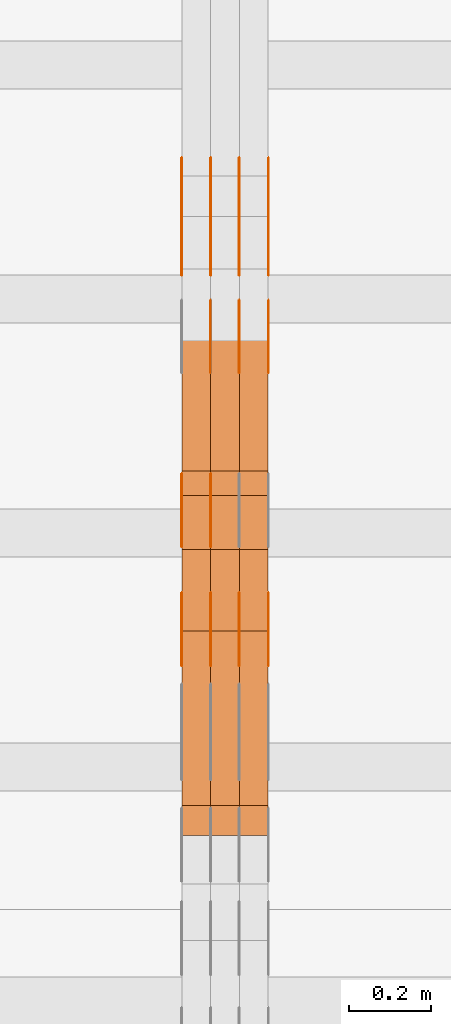
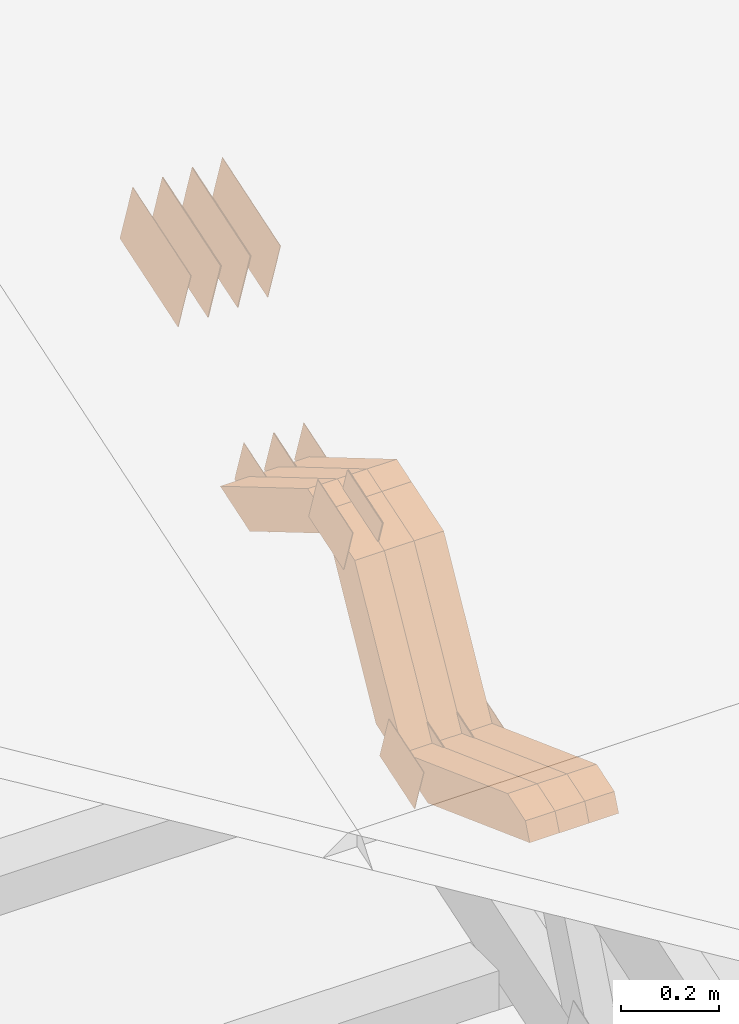
# One storey, part 137 of 385: 28 proxies.
"""IFC2X3 building model written with IfcOpenShell, lengths in millimetres."""

import ifcopenshell
import ifcopenshell.guid

model = None  # the IFC model being written
_history = None  # IfcOwnerHistory: only IFC2X3 demands one
_inside = {}  # id of a spatial element -> (the spatial element, [elements in it])
_under = {}  # id of a project, library or spatial element -> (it, [spatial elements below it])
_declared = {}  # id of a project -> (the project, [libraries it declares])
_typed = {}  # id of a type object -> (the type object, [elements of that type])
_made_of = {}  # id of a material, layer set ... -> (it, [elements and type objects made of it])


def new_model(schema):
    """Start an empty IFC model of exactly this schema.

    Asked for "IFC4X3", IfcOpenShell would pick the latest addendum, in which some entities
    have other attributes; the version numbers below select the first issue.
    IFC2X3 requires an IfcOwnerHistory on every rooted entity: one is made here for all.
    """
    global model, _history
    if schema == "IFC4X3":
        model = ifcopenshell.file(schema_version=(4, 3, 0, 0))
    else:
        model = ifcopenshell.file(schema=schema)
    _inside.clear()
    _under.clear()
    _declared.clear()
    _typed.clear()
    _made_of.clear()
    _history = None
    if model.schema == "IFC2X3":
        org = make("IfcOrganization", Name="unknown")
        user = make(
            "IfcPersonAndOrganization",
            ThePerson=make("IfcPerson", FamilyName="unknown"),
            TheOrganization=org,
        )
        app = make(
            "IfcApplication",
            ApplicationDeveloper=org,
            Version="unknown",
            ApplicationFullName="unknown",
            ApplicationIdentifier="unknown",
        )
        _history = make(
            "IfcOwnerHistory",
            OwningUser=user,
            OwningApplication=app,
            ChangeAction="ADDED",
            CreationDate=0,
        )
    return model


def make(cls, **values):
    """One entity of the class cls with the attributes given. An attribute that is None is left unset."""
    return model.create_entity(
        cls, **{name: value for name, value in values.items() if value is not None}
    )


def entity(cls, *values):
    """Any entity or typed value of the class cls, its attributes in the order of the schema. None: left unset."""
    e = model.create_entity(cls)
    for i, value in enumerate(values):
        if value is not None:
            e[i] = value
    return e


def rooted(cls, **values):
    """An entity with a GlobalId (a new one), such as an element, a storey or a relation."""
    return make(cls, GlobalId=ifcopenshell.guid.new(), OwnerHistory=_history, **values)


def si_unit(unit_type, name, prefix=None):
    """IfcSIUnit, for example si_unit("LENGTHUNIT", "METRE", prefix="MILLI")."""
    return make("IfcSIUnit", UnitType=unit_type, Prefix=prefix, Name=name)


def converted_unit(unit_type, name, factor, base, dimensions=None, offset=None):
    """IfcConversionBasedUnit, such as the inch: factor (a typed value) times the base unit."""
    return make(
        "IfcConversionBasedUnit"
        if offset is None
        else "IfcConversionBasedUnitWithOffset",
        ConversionOffset=offset,
        Dimensions=None
        if dimensions is None
        else entity("IfcDimensionalExponents", *dimensions),
        UnitType=unit_type,
        Name=name,
        ConversionFactor=make(
            "IfcMeasureWithUnit", ValueComponent=factor, UnitComponent=base
        ),
    )


def derived_unit(unit_type, elements):
    """IfcDerivedUnit: a product of units, each with its exponent."""
    return make(
        "IfcDerivedUnit",
        Elements=[
            make("IfcDerivedUnitElement", Unit=unit, Exponent=power)
            for unit, power in elements
        ],
        UnitType=unit_type,
    )


def assignment(units):
    """IfcUnitAssignment: the units of a project."""
    return None if units is None else make("IfcUnitAssignment", Units=units)


def point(xyz):
    """IfcCartesianPoint."""
    return None if xyz is None else make("IfcCartesianPoint", Coordinates=xyz)


def direction(xyz):
    """IfcDirection."""
    return None if xyz is None else make("IfcDirection", DirectionRatios=xyz)


def frame(location, z_axis=None, x_axis=None):
    """IfcAxis2Placement3D, a coordinate frame: its origin and axes. An axis left out is left unset."""
    return make(
        "IfcAxis2Placement3D",
        Location=point(location),
        Axis=direction(z_axis),
        RefDirection=direction(x_axis),
    )


def origin():
    """The frame at (0, 0, 0) with its axes left unset."""
    return frame((0.0, 0.0, 0.0))


def place(relative_to, where):
    """IfcLocalPlacement: puts the frame where relative to a parent placement (None: the world)."""
    return make(
        "IfcLocalPlacement", PlacementRelTo=relative_to, RelativePlacement=where
    )


def context(
    kind, dimensions, precision=None, world=None, true_north=None, identifier=None
):
    """IfcGeometricRepresentationContext, for example the 3D "Model" context."""
    return make(
        "IfcGeometricRepresentationContext",
        ContextIdentifier=identifier,
        ContextType=kind,
        CoordinateSpaceDimension=dimensions,
        Precision=precision,
        WorldCoordinateSystem=world,
        TrueNorth=true_north,
    )


def subcontext(parent, identifier, kind, view, scale=None):
    """IfcGeometricRepresentationSubContext, for example "Body" below "Model"."""
    return make(
        "IfcGeometricRepresentationSubContext",
        ContextIdentifier=identifier,
        ContextType=kind,
        ParentContext=parent,
        TargetScale=scale,
        TargetView=view,
    )


def project(units=None, contexts=None):
    """IfcProject with its units and contexts."""
    return rooted(
        "IfcProject",
        Name="project",
        RepresentationContexts=contexts,
        UnitsInContext=assignment(units),
    )


def spatial(cls, under=None, at=None, **own):
    """A site, building, storey or space (cls), placed at a placement, below another one or the project."""
    s = rooted(cls, ObjectPlacement=at, **own)
    if under is not None:
        _under.setdefault(under.id(), (under, []))[1].append(s)
    return s


def polyline(points):
    """IfcPolyline through the points."""
    return make("IfcPolyline", Points=[point(p) for p in points])


def outline(outer, holes=None, kind="AREA"):
    """IfcArbitraryClosedProfileDef: a profile drawn as a closed curve; with holes, ...WithVoids."""
    if holes is None:
        return make("IfcArbitraryClosedProfileDef", ProfileType=kind, OuterCurve=outer)
    return make(
        "IfcArbitraryProfileDefWithVoids",
        ProfileType=kind,
        OuterCurve=outer,
        InnerCurves=holes,
    )


def extrude(swept, where, along, depth):
    """IfcExtrudedAreaSolid: the profile swept, set in the frame where, extruded along a direction by depth."""
    return make(
        "IfcExtrudedAreaSolid",
        SweptArea=swept,
        Position=where,
        ExtrudedDirection=direction(along),
        Depth=depth,
    )


def shape(context_of_items, identifier, shape_type, items):
    """IfcShapeRepresentation: the items that make up one representation, for example the "Body"."""
    return make(
        "IfcShapeRepresentation",
        ContextOfItems=context_of_items,
        RepresentationIdentifier=identifier,
        RepresentationType=shape_type,
        Items=items,
    )


def source(mapping_origin, context_of_items, identifier, shape_type, items):
    """IfcRepresentationMap: a shape defined once, which mapped items show again and again."""
    return make(
        "IfcRepresentationMap",
        MappingOrigin=mapping_origin,
        MappedRepresentation=shape(context_of_items, identifier, shape_type, items),
    )


def transform(
    local_origin,
    x_axis=None,
    y_axis=None,
    z_axis=None,
    scale=None,
    scale2=None,
    scale3=None,
    uniform=True,
):
    """IfcCartesianTransformationOperator3D, or its non-uniform kind. x_axis, y_axis, z_axis: its Axis1, 2, 3."""
    if uniform:
        return make(
            "IfcCartesianTransformationOperator3D",
            Axis1=direction(x_axis),
            Axis2=direction(y_axis),
            LocalOrigin=point(local_origin),
            Scale=scale,
            Axis3=direction(z_axis),
        )
    return make(
        "IfcCartesianTransformationOperator3DnonUniform",
        Axis1=direction(x_axis),
        Axis2=direction(y_axis),
        LocalOrigin=point(local_origin),
        Scale=scale,
        Axis3=direction(z_axis),
        Scale2=scale2,
        Scale3=scale3,
    )


def mapped(mapping_source, mapping_target):
    """IfcMappedItem: shows the shape of a source again, moved by a transform."""
    return make(
        "IfcMappedItem", MappingSource=mapping_source, MappingTarget=mapping_target
    )


def material(Name=None, Category=None):
    """IfcMaterial."""
    return make("IfcMaterial", Name=Name, Category=Category)


def made_of(thing, what):
    """Note that an element or type object is made of a material, layer set ...; save() writes the relation."""
    if what is not None:
        _made_of.setdefault(what.id(), (what, []))[1].append(thing)
    return thing


def type_object(cls, material=None, **own):
    """A type object (cls), such as IfcWallType, which elements share."""
    return made_of(rooted(cls, **own), material)


def type_shapes(of_type, sources):
    """Give a type object the sources (RepresentationMaps) that its elements show as mapped items."""
    of_type.RepresentationMaps = sources


def element(
    cls,
    number,
    at=None,
    inside=None,
    cuts=None,
    type_object=None,
    material=None,
    context=None,
    identifier="Body",
    shape_type=None,
    held_by="IfcProductDefinitionShape",
    body=None,
    shapes=None,
    **own,
):
    """One element of the class cls, such as IfcWall. Its Tag is "e" and its number.

    at: its placement. inside: the storey or other place that contains it. cuts: it is an
    opening in that element (IfcRelVoidsElement). A single representation is given by context,
    identifier, shape_type and body (its items); several are given by shapes. held_by: the class
    of the entity that holds the representations. save() writes the other relations.
    """
    e = rooted(cls, Tag="e%d" % number, ObjectPlacement=at, **own)
    if body is not None:
        shapes = [shape(context, identifier, shape_type, body)]
    if shapes is not None:
        e.Representation = make(held_by, Representations=shapes)
    if inside is not None:
        _inside.setdefault(inside.id(), (inside, []))[1].append(e)
    if cuts is not None:
        rooted(
            "IfcRelVoidsElement", RelatingBuildingElement=cuts, RelatedOpeningElement=e
        )
    if type_object is not None:
        _typed.setdefault(type_object.id(), (type_object, []))[1].append(e)
    return made_of(e, material)


def aggregate(whole, parts):
    """IfcRelAggregates: a whole, such as a stair, and the parts it consists of."""
    return rooted("IfcRelAggregates", RelatingObject=whole, RelatedObjects=parts)


def save(model, path):
    """Write the relations noted so far, then the file.

    IfcRelAggregates (storeys below a building ...), IfcRelContainedInSpatialStructure (elements
    in a storey), IfcRelDefinesByType, IfcRelAssociatesMaterial and IfcRelDeclares: one each for
    every whole, place, type object, material and project.
    """
    for whole, parts in _under.values():
        aggregate(whole, parts)
    for where, things in _inside.values():
        rooted(
            "IfcRelContainedInSpatialStructure",
            RelatedElements=things,
            RelatingStructure=where,
        )
    for kind, things in _typed.values():
        rooted("IfcRelDefinesByType", RelatedObjects=things, RelatingType=kind)
    for what, things in _made_of.values():
        rooted("IfcRelAssociatesMaterial", RelatedObjects=things, RelatingMaterial=what)
    for by, libraries in _declared.values():
        rooted("IfcRelDeclares", RelatingContext=by, RelatedDefinitions=libraries)
    model.write(path)


model = new_model("IFC2X3")

# Units and contexts
model_context = context("Model", 3, precision=0.01, world=origin(), true_north=direction((6.12303176911189e-17, 1.0)))
body_context = subcontext(model_context, "Body", "Model", "MODEL_VIEW")
ifc_project = project(units=[si_unit("LENGTHUNIT", "METRE", prefix="MILLI"), si_unit("AREAUNIT", "SQUARE_METRE"), si_unit("VOLUMEUNIT", "CUBIC_METRE"), converted_unit("PLANEANGLEUNIT", "DEGREE", entity("IfcRatioMeasure", 0.0174532925199433), si_unit("PLANEANGLEUNIT", "RADIAN"), dimensions=[0, 0, 0, 0, 0, 0, 0]), si_unit("MASSUNIT", "GRAM", prefix="KILO"), derived_unit("MASSDENSITYUNIT", [(si_unit("MASSUNIT", "GRAM", prefix="KILO"), 1), (si_unit("LENGTHUNIT", "METRE"), -3)]), si_unit("TIMEUNIT", "SECOND"), si_unit("FREQUENCYUNIT", "HERTZ"), si_unit("THERMODYNAMICTEMPERATUREUNIT", "DEGREE_CELSIUS"), derived_unit("THERMALTRANSMITTANCEUNIT", [(si_unit("MASSUNIT", "GRAM", prefix="KILO"), 1), (si_unit("THERMODYNAMICTEMPERATUREUNIT", "KELVIN"), -1), (si_unit("TIMEUNIT", "SECOND"), -3)]), derived_unit("VOLUMETRICFLOWRATEUNIT", [(si_unit("LENGTHUNIT", "METRE"), 3), (si_unit("TIMEUNIT", "SECOND"), -1)]), si_unit("ELECTRICCURRENTUNIT", "AMPERE"), si_unit("ELECTRICVOLTAGEUNIT", "VOLT"), si_unit("POWERUNIT", "WATT"), si_unit("FORCEUNIT", "NEWTON", prefix="KILO"), si_unit("ILLUMINANCEUNIT", "LUX"), si_unit("LUMINOUSFLUXUNIT", "LUMEN"), si_unit("LUMINOUSINTENSITYUNIT", "CANDELA"), derived_unit("USERDEFINED", [(si_unit("MASSUNIT", "GRAM", prefix="KILO"), -1), (si_unit("LENGTHUNIT", "METRE"), -2), (si_unit("TIMEUNIT", "SECOND"), 3), (si_unit("LUMINOUSFLUXUNIT", "LUMEN"), 1)]), derived_unit("LINEARVELOCITYUNIT", [(si_unit("LENGTHUNIT", "METRE"), 1), (si_unit("TIMEUNIT", "SECOND"), -1)]), si_unit("PRESSUREUNIT", "PASCAL"), derived_unit("USERDEFINED", [(si_unit("LENGTHUNIT", "METRE"), -2), (si_unit("MASSUNIT", "GRAM", prefix="KILO"), 1), (si_unit("TIMEUNIT", "SECOND"), -2)])], contexts=[model_context])

# Site, building, storey
site_placement = place(None, origin())
site = spatial("IfcSite", under=ifc_project, at=site_placement, CompositionType="ELEMENT")
building_placement = place(site_placement, origin())
building = spatial("IfcBuilding", under=site, at=building_placement, CompositionType="ELEMENT")
storey_placement = place(building_placement, origin())
storey = spatial("IfcBuildingStorey", under=building, at=storey_placement, Name="Default", CompositionType="ELEMENT", Elevation=0.0)

# Proxies
ifc_material_1 = material(Name="IfcSurfaceStyle #348749")
building_element_proxy_type_1 = type_object("IfcBuildingElementProxyType", PredefinedType="NOTDEFINED", material=ifc_material_1)
shared_shape_1 = source(origin(), body_context, "Body", "SweptSolid", [
    extrude(outline(polyline([(-74.9998754286207, -60.0000016373506), (74.9998605591063, -60.0000016373506), (74.9998754286244, 60.0000016373506), (-74.9998605591099, 60.0000016373506), (-74.9998754286207, -60.0000016373506)])), frame((74.9998754286244, 60.0000016373506, 0.0), z_axis=(0.0, 0.0, 1.0), x_axis=(-1.0, 0.0, 0.0)), (0.0, 0.0, 1.0), 1.29999999999999),
])
type_shapes(building_element_proxy_type_1, [shared_shape_1])
proxy_1_placement = place(building_placement, frame((27245.0, 9580.89841427132, 2615.81135078741), z_axis=(-1.0, 0.0, 0.0), x_axis=(0.0, 0.951056516295154, 0.309016994374948)))
element("IfcBuildingElementProxy", 1, at=proxy_1_placement, inside=storey, type_object=building_element_proxy_type_1, material=ifc_material_1, context=body_context, shape_type="MappedRepresentation", body=[
    mapped(shared_shape_1, transform((0.0, 0.0, 0.0), scale=1.0)),
])
ifc_material_2 = material(Name="IfcSurfaceStyle #348692")
building_element_proxy_type_2 = type_object("IfcBuildingElementProxyType", PredefinedType="NOTDEFINED", material=ifc_material_2)
shared_shape_2 = source(origin(), body_context, "Body", "SweptSolid", [
    extrude(outline(polyline([(-74.9998754286207, -60.0000016373506), (74.9998605591063, -60.0000016373506), (74.9998754286244, 60.0000016373506), (-74.9998605591099, 60.0000016373506), (-74.9998754286207, -60.0000016373506)])), frame((74.9998754286244, 60.0000016373506, 0.0), z_axis=(0.0, 0.0, 1.0), x_axis=(-1.0, 0.0, 0.0)), (0.0, 0.0, 1.0), 1.29999999999999),
])
type_shapes(building_element_proxy_type_2, [shared_shape_2])
proxy_2_placement = place(building_placement, frame((27246.3, 9580.89841427132, 2615.81135078741), z_axis=(-1.0, 0.0, 0.0), x_axis=(0.0, 0.951056516295154, 0.309016994374948)))
element("IfcBuildingElementProxy", 2, at=proxy_2_placement, inside=storey, type_object=building_element_proxy_type_2, material=ifc_material_2, context=body_context, shape_type="MappedRepresentation", body=[
    mapped(shared_shape_2, transform((0.0, 0.0, 0.0), scale=1.0)),
])
ifc_material_3 = material(Name="IfcSurfaceStyle #348635")
building_element_proxy_type_3 = type_object("IfcBuildingElementProxyType", PredefinedType="NOTDEFINED", material=ifc_material_3)
shared_shape_3 = source(origin(), body_context, "Body", "SweptSolid", [
    extrude(outline(polyline([(-74.9998754286207, -60.0000016373506), (74.9998605591063, -60.0000016373506), (74.9998754286244, 60.0000016373506), (-74.9998605591099, 60.0000016373506), (-74.9998754286207, -60.0000016373506)])), frame((74.9998754286244, 60.0000016373506, 0.0), z_axis=(0.0, 0.0, 1.0), x_axis=(-1.0, 0.0, 0.0)), (0.0, 0.0, 1.0), 1.29999999999999),
])
type_shapes(building_element_proxy_type_3, [shared_shape_3])
proxy_3_placement = place(building_placement, frame((27175.0, 9580.89841427132, 2615.81135078741), z_axis=(-1.0, 0.0, 0.0), x_axis=(0.0, 0.951056516295154, 0.309016994374948)))
element("IfcBuildingElementProxy", 3, at=proxy_3_placement, inside=storey, type_object=building_element_proxy_type_3, material=ifc_material_3, context=body_context, shape_type="MappedRepresentation", body=[
    mapped(shared_shape_3, transform((0.0, 0.0, 0.0), scale=1.0)),
])
ifc_material_4 = material(Name="IfcSurfaceStyle #347894")
building_element_proxy_type_4 = type_object("IfcBuildingElementProxyType", PredefinedType="NOTDEFINED", material=ifc_material_4)
shared_shape_4 = source(origin(), body_context, "Body", "SweptSolid", [
    extrude(outline(polyline([(-75.0008041947458, -59.9996998629349), (75.0007893252423, -59.9996998629349), (75.0008041947458, 59.9996998629349), (-75.0007893252423, 59.9996998629349), (-75.0008041947458, -59.9996998629349)])), frame((75.0008041947458, 60.0002282421692, 0.0), z_axis=(0.0, 0.0, 1.0), x_axis=(-1.0, 0.0, 0.0)), (0.0, 0.0, 1.0), 1.3),
])
type_shapes(building_element_proxy_type_4, [shared_shape_4])
proxy_4_placement = place(building_placement, frame((27386.3, 9291.048828125, 2194.94482421875), z_axis=(-1.0, 0.0, 0.0), x_axis=(0.0, 0.951056516295124, 0.309016994375039)))
element("IfcBuildingElementProxy", 4, at=proxy_4_placement, inside=storey, type_object=building_element_proxy_type_4, material=ifc_material_4, context=body_context, shape_type="MappedRepresentation", body=[
    mapped(shared_shape_4, transform((0.0, 0.0, 0.0), scale=1.0)),
])
ifc_material_5 = material(Name="IfcSurfaceStyle #347837")
building_element_proxy_type_5 = type_object("IfcBuildingElementProxyType", PredefinedType="NOTDEFINED", material=ifc_material_5)
shared_shape_5 = source(origin(), body_context, "Body", "SweptSolid", [
    extrude(outline(polyline([(-75.0008041947458, -59.9996998629349), (75.0007893252423, -59.9996998629349), (75.0008041947458, 59.9996998629349), (-75.0007893252423, 59.9996998629349), (-75.0008041947458, -59.9996998629349)])), frame((75.0008041947458, 60.0002282421692, 0.0), z_axis=(0.0, 0.0, 1.0), x_axis=(-1.0, 0.0, 0.0)), (0.0, 0.0, 1.0), 1.3),
])
type_shapes(building_element_proxy_type_5, [shared_shape_5])
proxy_5_placement = place(building_placement, frame((27315.0, 9291.048828125, 2194.94482421875), z_axis=(-1.0, 0.0, 0.0), x_axis=(0.0, 0.951056516295124, 0.309016994375039)))
element("IfcBuildingElementProxy", 5, at=proxy_5_placement, inside=storey, type_object=building_element_proxy_type_5, material=ifc_material_5, context=body_context, shape_type="MappedRepresentation", body=[
    mapped(shared_shape_5, transform((0.0, 0.0, 0.0), scale=1.0)),
])
ifc_material_6 = material(Name="IfcSurfaceStyle #347780")
building_element_proxy_type_6 = type_object("IfcBuildingElementProxyType", PredefinedType="NOTDEFINED", material=ifc_material_6)
shared_shape_6 = source(origin(), body_context, "Body", "SweptSolid", [
    extrude(outline(polyline([(-75.0008041947458, -59.9996998629349), (75.0007893252423, -59.9996998629349), (75.0008041947458, 59.9996998629349), (-75.0007893252423, 59.9996998629349), (-75.0008041947458, -59.9996998629349)])), frame((75.0008041947458, 60.0002282421692, 0.0), z_axis=(0.0, 0.0, 1.0), x_axis=(-1.0, 0.0, 0.0)), (0.0, 0.0, 1.0), 1.3),
])
type_shapes(building_element_proxy_type_6, [shared_shape_6])
proxy_6_placement = place(building_placement, frame((27316.3, 9291.048828125, 2194.94482421875), z_axis=(-1.0, 0.0, 0.0), x_axis=(0.0, 0.951056516295124, 0.309016994375039)))
element("IfcBuildingElementProxy", 6, at=proxy_6_placement, inside=storey, type_object=building_element_proxy_type_6, material=ifc_material_6, context=body_context, shape_type="MappedRepresentation", body=[
    mapped(shared_shape_6, transform((0.0, 0.0, 0.0), scale=1.0)),
])
ifc_material_7 = material(Name="IfcSurfaceStyle #347723")
building_element_proxy_type_7 = type_object("IfcBuildingElementProxyType", PredefinedType="NOTDEFINED", material=ifc_material_7)
shared_shape_7 = source(origin(), body_context, "Body", "SweptSolid", [
    extrude(outline(polyline([(-75.0008041947458, -59.9996998629349), (75.0007893252423, -59.9996998629349), (75.0008041947458, 59.9996998629349), (-75.0007893252423, 59.9996998629349), (-75.0008041947458, -59.9996998629349)])), frame((75.0008041947458, 60.0002282421692, 0.0), z_axis=(0.0, 0.0, 1.0), x_axis=(-1.0, 0.0, 0.0)), (0.0, 0.0, 1.0), 1.29999999999999),
])
type_shapes(building_element_proxy_type_7, [shared_shape_7])
proxy_7_placement = place(building_placement, frame((27245.0, 9291.048828125, 2194.94482421875), z_axis=(-1.0, 0.0, 0.0), x_axis=(0.0, 0.951056516295124, 0.309016994375039)))
element("IfcBuildingElementProxy", 7, at=proxy_7_placement, inside=storey, type_object=building_element_proxy_type_7, material=ifc_material_7, context=body_context, shape_type="MappedRepresentation", body=[
    mapped(shared_shape_7, transform((0.0, 0.0, 0.0), scale=1.0)),
])
ifc_material_8 = material(Name="IfcSurfaceStyle #347666")
building_element_proxy_type_8 = type_object("IfcBuildingElementProxyType", PredefinedType="NOTDEFINED", material=ifc_material_8)
shared_shape_8 = source(origin(), body_context, "Body", "SweptSolid", [
    extrude(outline(polyline([(-75.0008041947458, -59.9996998629349), (75.0007893252423, -59.9996998629349), (75.0008041947458, 59.9996998629349), (-75.0007893252423, 59.9996998629349), (-75.0008041947458, -59.9996998629349)])), frame((75.0008041947458, 60.0002282421692, 0.0), z_axis=(0.0, 0.0, 1.0), x_axis=(-1.0, 0.0, 0.0)), (0.0, 0.0, 1.0), 1.29999999999999),
])
type_shapes(building_element_proxy_type_8, [shared_shape_8])
proxy_8_placement = place(building_placement, frame((27246.3, 9291.048828125, 2194.94482421875), z_axis=(-1.0, 0.0, 0.0), x_axis=(0.0, 0.951056516295124, 0.309016994375039)))
element("IfcBuildingElementProxy", 8, at=proxy_8_placement, inside=storey, type_object=building_element_proxy_type_8, material=ifc_material_8, context=body_context, shape_type="MappedRepresentation", body=[
    mapped(shared_shape_8, transform((0.0, 0.0, 0.0), scale=1.0)),
])
ifc_material_9 = material(Name="IfcSurfaceStyle #347609")
building_element_proxy_type_9 = type_object("IfcBuildingElementProxyType", PredefinedType="NOTDEFINED", material=ifc_material_9)
shared_shape_9 = source(origin(), body_context, "Body", "SweptSolid", [
    extrude(outline(polyline([(-75.0008041947458, -59.9996998629349), (75.0007893252423, -59.9996998629349), (75.0008041947458, 59.9996998629349), (-75.0007893252423, 59.9996998629349), (-75.0008041947458, -59.9996998629349)])), frame((75.0008041947458, 60.0002282421692, 0.0), z_axis=(0.0, 0.0, 1.0), x_axis=(-1.0, 0.0, 0.0)), (0.0, 0.0, 1.0), 1.29999999999999),
])
type_shapes(building_element_proxy_type_9, [shared_shape_9])
proxy_9_placement = place(building_placement, frame((27175.0, 9291.048828125, 2194.94482421875), z_axis=(-1.0, 0.0, 0.0), x_axis=(0.0, 0.951056516295124, 0.309016994375039)))
element("IfcBuildingElementProxy", 9, at=proxy_9_placement, inside=storey, type_object=building_element_proxy_type_9, material=ifc_material_9, context=body_context, shape_type="MappedRepresentation", body=[
    mapped(shared_shape_9, transform((0.0, 0.0, 0.0), scale=1.0)),
])
ifc_material_10 = material(Name="IfcSurfaceStyle #347552")
building_element_proxy_type_10 = type_object("IfcBuildingElementProxyType", PredefinedType="NOTDEFINED", material=ifc_material_10)
shared_shape_10 = source(origin(), body_context, "Body", "SweptSolid", [
    extrude(outline(polyline([(-124.999432723313, -83.9999457831645), (125.000177551971, -83.9999457831645), (124.999395001513, 83.9999457831646), (-125.000139830171, 83.9999457831645), (-124.999432723313, -83.9999457831645)])), frame((125.000177551971, 84.0001194377192, 0.0), z_axis=(0.0, 0.0, 1.0), x_axis=(-1.0, 0.0, 0.0)), (0.0, 0.0, 1.0), 1.3),
])
type_shapes(building_element_proxy_type_10, [shared_shape_10])
proxy_10_placement = place(building_placement, frame((27386.3, 10242.0968435407, 2855.88278137571), z_axis=(-1.0, 0.0, 0.0), x_axis=(0.0, 0.951056516295154, 0.309016994374948)))
element("IfcBuildingElementProxy", 10, at=proxy_10_placement, inside=storey, type_object=building_element_proxy_type_10, material=ifc_material_10, context=body_context, shape_type="MappedRepresentation", body=[
    mapped(shared_shape_10, transform((0.0, 0.0, 0.0), scale=1.0)),
])
ifc_material_11 = material(Name="IfcSurfaceStyle #347495")
building_element_proxy_type_11 = type_object("IfcBuildingElementProxyType", PredefinedType="NOTDEFINED", material=ifc_material_11)
shared_shape_11 = source(origin(), body_context, "Body", "SweptSolid", [
    extrude(outline(polyline([(-124.999432723313, -83.9999457831645), (125.000177551971, -83.9999457831645), (124.999395001513, 83.9999457831646), (-125.000139830171, 83.9999457831645), (-124.999432723313, -83.9999457831645)])), frame((125.000177551971, 84.0001194377192, 0.0), z_axis=(0.0, 0.0, 1.0), x_axis=(-1.0, 0.0, 0.0)), (0.0, 0.0, 1.0), 1.3),
])
type_shapes(building_element_proxy_type_11, [shared_shape_11])
proxy_11_placement = place(building_placement, frame((27315.0, 10242.0968435407, 2855.88278137571), z_axis=(-1.0, 0.0, 0.0), x_axis=(0.0, 0.951056516295154, 0.309016994374948)))
element("IfcBuildingElementProxy", 11, at=proxy_11_placement, inside=storey, type_object=building_element_proxy_type_11, material=ifc_material_11, context=body_context, shape_type="MappedRepresentation", body=[
    mapped(shared_shape_11, transform((0.0, 0.0, 0.0), scale=1.0)),
])
ifc_material_12 = material(Name="IfcSurfaceStyle #347438")
building_element_proxy_type_12 = type_object("IfcBuildingElementProxyType", PredefinedType="NOTDEFINED", material=ifc_material_12)
shared_shape_12 = source(origin(), body_context, "Body", "SweptSolid", [
    extrude(outline(polyline([(-124.999432723313, -83.9999457831645), (125.000177551971, -83.9999457831645), (124.999395001513, 83.9999457831646), (-125.000139830171, 83.9999457831645), (-124.999432723313, -83.9999457831645)])), frame((125.000177551971, 84.0001194377192, 0.0), z_axis=(0.0, 0.0, 1.0), x_axis=(-1.0, 0.0, 0.0)), (0.0, 0.0, 1.0), 1.3),
])
type_shapes(building_element_proxy_type_12, [shared_shape_12])
proxy_12_placement = place(building_placement, frame((27316.3, 10242.0968435407, 2855.88278137571), z_axis=(-1.0, 0.0, 0.0), x_axis=(0.0, 0.951056516295154, 0.309016994374948)))
element("IfcBuildingElementProxy", 12, at=proxy_12_placement, inside=storey, type_object=building_element_proxy_type_12, material=ifc_material_12, context=body_context, shape_type="MappedRepresentation", body=[
    mapped(shared_shape_12, transform((0.0, 0.0, 0.0), scale=1.0)),
])
ifc_material_13 = material(Name="IfcSurfaceStyle #347381")
building_element_proxy_type_13 = type_object("IfcBuildingElementProxyType", PredefinedType="NOTDEFINED", material=ifc_material_13)
shared_shape_13 = source(origin(), body_context, "Body", "SweptSolid", [
    extrude(outline(polyline([(-124.999432723313, -83.9999457831645), (125.000177551971, -83.9999457831645), (124.999395001513, 83.9999457831646), (-125.000139830171, 83.9999457831645), (-124.999432723313, -83.9999457831645)])), frame((125.000177551971, 84.0001194377192, 0.0), z_axis=(0.0, 0.0, 1.0), x_axis=(-1.0, 0.0, 0.0)), (0.0, 0.0, 1.0), 1.29999999999998),
])
type_shapes(building_element_proxy_type_13, [shared_shape_13])
proxy_13_placement = place(building_placement, frame((27245.0, 10242.0968435407, 2855.88278137571), z_axis=(-1.0, 0.0, 0.0), x_axis=(0.0, 0.951056516295154, 0.309016994374948)))
element("IfcBuildingElementProxy", 13, at=proxy_13_placement, inside=storey, type_object=building_element_proxy_type_13, material=ifc_material_13, context=body_context, shape_type="MappedRepresentation", body=[
    mapped(shared_shape_13, transform((0.0, 0.0, 0.0), scale=1.0)),
])
ifc_material_14 = material(Name="IfcSurfaceStyle #347324")
building_element_proxy_type_14 = type_object("IfcBuildingElementProxyType", PredefinedType="NOTDEFINED", material=ifc_material_14)
shared_shape_14 = source(origin(), body_context, "Body", "SweptSolid", [
    extrude(outline(polyline([(-124.999432723313, -83.9999457831645), (125.000177551971, -83.9999457831645), (124.999395001513, 83.9999457831646), (-125.000139830171, 83.9999457831645), (-124.999432723313, -83.9999457831645)])), frame((125.000177551971, 84.0001194377192, 0.0), z_axis=(0.0, 0.0, 1.0), x_axis=(-1.0, 0.0, 0.0)), (0.0, 0.0, 1.0), 1.29999999999998),
])
type_shapes(building_element_proxy_type_14, [shared_shape_14])
proxy_14_placement = place(building_placement, frame((27246.3, 10242.0968435407, 2855.88278137571), z_axis=(-1.0, 0.0, 0.0), x_axis=(0.0, 0.951056516295154, 0.309016994374948)))
element("IfcBuildingElementProxy", 14, at=proxy_14_placement, inside=storey, type_object=building_element_proxy_type_14, material=ifc_material_14, context=body_context, shape_type="MappedRepresentation", body=[
    mapped(shared_shape_14, transform((0.0, 0.0, 0.0), scale=1.0)),
])
ifc_material_15 = material(Name="IfcSurfaceStyle #347267")
building_element_proxy_type_15 = type_object("IfcBuildingElementProxyType", PredefinedType="NOTDEFINED", material=ifc_material_15)
shared_shape_15 = source(origin(), body_context, "Body", "SweptSolid", [
    extrude(outline(polyline([(-124.999432723313, -83.9999457831645), (125.000177551971, -83.9999457831645), (124.999395001513, 83.9999457831646), (-125.000139830171, 83.9999457831645), (-124.999432723313, -83.9999457831645)])), frame((125.000177551971, 84.0001194377192, 0.0), z_axis=(0.0, 0.0, 1.0), x_axis=(-1.0, 0.0, 0.0)), (0.0, 0.0, 1.0), 1.29999999999998),
])
type_shapes(building_element_proxy_type_15, [shared_shape_15])
proxy_15_placement = place(building_placement, frame((27175.0, 10242.0968435407, 2855.88278137571), z_axis=(-1.0, 0.0, 0.0), x_axis=(0.0, 0.951056516295154, 0.309016994374948)))
element("IfcBuildingElementProxy", 15, at=proxy_15_placement, inside=storey, type_object=building_element_proxy_type_15, material=ifc_material_15, context=body_context, shape_type="MappedRepresentation", body=[
    mapped(shared_shape_15, transform((0.0, 0.0, 0.0), scale=1.0)),
])
ifc_material_16 = material(Name="IfcSurfaceStyle #345842")
building_element_proxy_type_16 = type_object("IfcBuildingElementProxyType", PredefinedType="NOTDEFINED", material=ifc_material_16)
shared_shape_16 = source(origin(), body_context, "Body", "SweptSolid", [
    extrude(outline(polyline([(-74.9998754286189, -60.0000016373433), (74.9998605591118, -60.0000016373433), (74.9998754286189, 60.0000016373433), (-74.9998605591118, 60.0000016373433), (-74.9998754286189, -60.0000016373433)])), frame((74.9999131819004, 60.0000016373433, 0.0), z_axis=(0.0, 0.0, 1.0), x_axis=(-1.0, 0.0, 0.0)), (0.0, 0.0, 1.0), 1.3),
])
type_shapes(building_element_proxy_type_16, [shared_shape_16])
proxy_16_placement = place(building_placement, frame((27386.3, 10004.8612689908, 2426.87628052724), z_axis=(-1.0, 0.0, 0.0), x_axis=(0.0, 0.951056516295124, 0.309016994375039)))
element("IfcBuildingElementProxy", 16, at=proxy_16_placement, inside=storey, type_object=building_element_proxy_type_16, material=ifc_material_16, context=body_context, shape_type="MappedRepresentation", body=[
    mapped(shared_shape_16, transform((0.0, 0.0, 0.0), scale=1.0)),
])
ifc_material_17 = material(Name="IfcSurfaceStyle #345785")
building_element_proxy_type_17 = type_object("IfcBuildingElementProxyType", PredefinedType="NOTDEFINED", material=ifc_material_17)
shared_shape_17 = source(origin(), body_context, "Body", "SweptSolid", [
    extrude(outline(polyline([(-74.9998754286189, -60.0000016373433), (74.9998605591118, -60.0000016373433), (74.9998754286189, 60.0000016373433), (-74.9998605591118, 60.0000016373433), (-74.9998754286189, -60.0000016373433)])), frame((74.9999131819004, 60.0000016373433, 0.0), z_axis=(0.0, 0.0, 1.0), x_axis=(-1.0, 0.0, 0.0)), (0.0, 0.0, 1.0), 1.3),
])
type_shapes(building_element_proxy_type_17, [shared_shape_17])
proxy_17_placement = place(building_placement, frame((27315.0, 10004.8612689908, 2426.87628052724), z_axis=(-1.0, 0.0, 0.0), x_axis=(0.0, 0.951056516295124, 0.309016994375039)))
element("IfcBuildingElementProxy", 17, at=proxy_17_placement, inside=storey, type_object=building_element_proxy_type_17, material=ifc_material_17, context=body_context, shape_type="MappedRepresentation", body=[
    mapped(shared_shape_17, transform((0.0, 0.0, 0.0), scale=1.0)),
])
ifc_material_18 = material(Name="IfcSurfaceStyle #345728")
building_element_proxy_type_18 = type_object("IfcBuildingElementProxyType", PredefinedType="NOTDEFINED", material=ifc_material_18)
shared_shape_18 = source(origin(), body_context, "Body", "SweptSolid", [
    extrude(outline(polyline([(-74.9998754286189, -60.0000016373433), (74.9998605591118, -60.0000016373433), (74.9998754286189, 60.0000016373433), (-74.9998605591118, 60.0000016373433), (-74.9998754286189, -60.0000016373433)])), frame((74.9999131819004, 60.0000016373433, 0.0), z_axis=(0.0, 0.0, 1.0), x_axis=(-1.0, 0.0, 0.0)), (0.0, 0.0, 1.0), 1.3),
])
type_shapes(building_element_proxy_type_18, [shared_shape_18])
proxy_18_placement = place(building_placement, frame((27316.3, 10004.8612689908, 2426.87628052724), z_axis=(-1.0, 0.0, 0.0), x_axis=(0.0, 0.951056516295124, 0.309016994375039)))
element("IfcBuildingElementProxy", 18, at=proxy_18_placement, inside=storey, type_object=building_element_proxy_type_18, material=ifc_material_18, context=body_context, shape_type="MappedRepresentation", body=[
    mapped(shared_shape_18, transform((0.0, 0.0, 0.0), scale=1.0)),
])
ifc_material_19 = material(Name="IfcSurfaceStyle #345671")
building_element_proxy_type_19 = type_object("IfcBuildingElementProxyType", PredefinedType="NOTDEFINED", material=ifc_material_19)
shared_shape_19 = source(origin(), body_context, "Body", "SweptSolid", [
    extrude(outline(polyline([(-74.9998754286189, -60.0000016373433), (74.9998605591118, -60.0000016373433), (74.9998754286189, 60.0000016373433), (-74.9998605591118, 60.0000016373433), (-74.9998754286189, -60.0000016373433)])), frame((74.9999131819004, 60.0000016373433, 0.0), z_axis=(0.0, 0.0, 1.0), x_axis=(-1.0, 0.0, 0.0)), (0.0, 0.0, 1.0), 1.29999999999999),
])
type_shapes(building_element_proxy_type_19, [shared_shape_19])
proxy_19_placement = place(building_placement, frame((27245.0, 10004.8612689908, 2426.87628052724), z_axis=(-1.0, 0.0, 0.0), x_axis=(0.0, 0.951056516295124, 0.309016994375039)))
element("IfcBuildingElementProxy", 19, at=proxy_19_placement, inside=storey, type_object=building_element_proxy_type_19, material=ifc_material_19, context=body_context, shape_type="MappedRepresentation", body=[
    mapped(shared_shape_19, transform((0.0, 0.0, 0.0), scale=1.0)),
])
ifc_material_20 = material(Name="IfcSurfaceStyle #324728")
building_element_proxy_type_20 = type_object("IfcBuildingElementProxyType", Name="T1-W43 324726", PredefinedType="NOTDEFINED", material=ifc_material_20)
shared_shape_20 = source(origin(), body_context, "Body", "SweptSolid", [
    extrude(outline(polyline([(-198.159905426436, -47.4999961988362), (173.155878681738, -47.4999961988362), (174.585865234707, -0.00038778214839239), (132.582704932703, 47.5001900899104), (-282.164543422712, 47.5001900899104), (-198.159905426436, -47.4999961988362)])), frame((174.585865234707, 47.5001900899104, 0.0), z_axis=(0.0, 0.0, 1.0), x_axis=(-1.0, 0.0, 0.0)), (0.0, 0.0, 1.0), 70.0),
])
type_shapes(building_element_proxy_type_20, [shared_shape_20])
proxy_20_placement = place(building_placement, frame((27385.0, 9730.71877771152, 2634.4881681647), z_axis=(-1.0, 0.0, 0.0), x_axis=(0.0, 0.861495156633645, -0.507765787639115)))
element("IfcBuildingElementProxy", 20, at=proxy_20_placement, inside=storey, type_object=building_element_proxy_type_20, material=ifc_material_20, Name="T1-W43", context=body_context, shape_type="MappedRepresentation", body=[
    mapped(shared_shape_20, transform((0.0, 0.0, 0.0), scale=1.0)),
])
ifc_material_21 = material(Name="IfcSurfaceStyle #324662")
building_element_proxy_type_21 = type_object("IfcBuildingElementProxyType", Name="T1-W43 324660", PredefinedType="NOTDEFINED", material=ifc_material_21)
shared_shape_21 = source(origin(), body_context, "Body", "SweptSolid", [
    extrude(outline(polyline([(-198.159905426436, -47.4999961988362), (173.155878681738, -47.4999961988362), (174.585865234707, -0.00038778214839239), (132.582704932703, 47.5001900899104), (-282.164543422712, 47.5001900899104), (-198.159905426436, -47.4999961988362)])), frame((174.585865234707, 47.5001900899104, 0.0), z_axis=(0.0, 0.0, 1.0), x_axis=(-1.0, 0.0, 0.0)), (0.0, 0.0, 1.0), 70.0),
])
type_shapes(building_element_proxy_type_21, [shared_shape_21])
proxy_21_placement = place(building_placement, frame((27315.0, 9730.71877771152, 2634.4881681647), z_axis=(-1.0, 0.0, 0.0), x_axis=(0.0, 0.861495156633645, -0.507765787639115)))
element("IfcBuildingElementProxy", 21, at=proxy_21_placement, inside=storey, type_object=building_element_proxy_type_21, material=ifc_material_21, Name="T1-W43", context=body_context, shape_type="MappedRepresentation", body=[
    mapped(shared_shape_21, transform((0.0, 0.0, 0.0), scale=1.0)),
])
ifc_material_22 = material(Name="IfcSurfaceStyle #324596")
building_element_proxy_type_22 = type_object("IfcBuildingElementProxyType", Name="T1-W43 324594", PredefinedType="NOTDEFINED", material=ifc_material_22)
shared_shape_22 = source(origin(), body_context, "Body", "SweptSolid", [
    extrude(outline(polyline([(-198.159905426436, -47.4999961988362), (173.155878681738, -47.4999961988362), (174.585865234707, -0.00038778214839239), (132.582704932703, 47.5001900899104), (-282.164543422712, 47.5001900899104), (-198.159905426436, -47.4999961988362)])), frame((174.585865234707, 47.5001900899104, 0.0), z_axis=(0.0, 0.0, 1.0), x_axis=(-1.0, 0.0, 0.0)), (0.0, 0.0, 1.0), 70.0),
])
type_shapes(building_element_proxy_type_22, [shared_shape_22])
proxy_22_placement = place(building_placement, frame((27245.0, 9730.71877771152, 2634.4881681647), z_axis=(-1.0, 0.0, 0.0), x_axis=(0.0, 0.861495156633645, -0.507765787639115)))
element("IfcBuildingElementProxy", 22, at=proxy_22_placement, inside=storey, type_object=building_element_proxy_type_22, material=ifc_material_22, Name="T1-W43", context=body_context, shape_type="MappedRepresentation", body=[
    mapped(shared_shape_22, transform((0.0, 0.0, 0.0), scale=1.0)),
])
ifc_material_23 = material(Name="IfcSurfaceStyle #324332")
building_element_proxy_type_23 = type_object("IfcBuildingElementProxyType", Name="T1-W33 324330", PredefinedType="NOTDEFINED", material=ifc_material_23)
shared_shape_23 = source(origin(), body_context, "Body", "SweptSolid", [
    extrude(outline(polyline([(-314.173070820175, -47.4997758466969), (139.635944117881, -47.4997758466969), (190.204920608233, 0.000348187720347082), (197.369205310989, 47.5001702328475), (-213.036999216928, 47.4990332728259), (-314.173070820175, -47.4997758466969)])), frame((197.369205310989, 47.5001702328475, 0.0), z_axis=(0.0, 0.0, 1.0), x_axis=(-1.0, 0.0, 0.0)), (0.0, 0.0, 1.0), 70.0),
])
type_shapes(building_element_proxy_type_23, [shared_shape_23])
proxy_23_placement = place(building_placement, frame((27385.0, 9376.96875, 2191.01977539063), z_axis=(-1.0, 0.0, 0.0), x_axis=(0.0, 0.481632628948835, 0.876373214293907)))
element("IfcBuildingElementProxy", 23, at=proxy_23_placement, inside=storey, type_object=building_element_proxy_type_23, material=ifc_material_23, Name="T1-W33", context=body_context, shape_type="MappedRepresentation", body=[
    mapped(shared_shape_23, transform((0.0, 0.0, 0.0), scale=1.0)),
])
ifc_material_24 = material(Name="IfcSurfaceStyle #324266")
building_element_proxy_type_24 = type_object("IfcBuildingElementProxyType", Name="T1-W33 324264", PredefinedType="NOTDEFINED", material=ifc_material_24)
shared_shape_24 = source(origin(), body_context, "Body", "SweptSolid", [
    extrude(outline(polyline([(-314.173070820175, -47.4997758466969), (139.635944117881, -47.4997758466969), (190.204920608233, 0.000348187720347082), (197.369205310989, 47.5001702328475), (-213.036999216928, 47.4990332728259), (-314.173070820175, -47.4997758466969)])), frame((197.369205310989, 47.5001702328475, 0.0), z_axis=(0.0, 0.0, 1.0), x_axis=(-1.0, 0.0, 0.0)), (0.0, 0.0, 1.0), 70.0),
])
type_shapes(building_element_proxy_type_24, [shared_shape_24])
proxy_24_placement = place(building_placement, frame((27315.0, 9376.96875, 2191.01977539063), z_axis=(-1.0, 0.0, 0.0), x_axis=(0.0, 0.481632628948835, 0.876373214293907)))
element("IfcBuildingElementProxy", 24, at=proxy_24_placement, inside=storey, type_object=building_element_proxy_type_24, material=ifc_material_24, Name="T1-W33", context=body_context, shape_type="MappedRepresentation", body=[
    mapped(shared_shape_24, transform((0.0, 0.0, 0.0), scale=1.0)),
])
ifc_material_25 = material(Name="IfcSurfaceStyle #324200")
building_element_proxy_type_25 = type_object("IfcBuildingElementProxyType", Name="T1-W33 324198", PredefinedType="NOTDEFINED", material=ifc_material_25)
shared_shape_25 = source(origin(), body_context, "Body", "SweptSolid", [
    extrude(outline(polyline([(-314.173070820175, -47.4997758466969), (139.635944117881, -47.4997758466969), (190.204920608233, 0.000348187720347082), (197.369205310989, 47.5001702328475), (-213.036999216928, 47.4990332728259), (-314.173070820175, -47.4997758466969)])), frame((197.369205310989, 47.5001702328475, 0.0), z_axis=(0.0, 0.0, 1.0), x_axis=(-1.0, 0.0, 0.0)), (0.0, 0.0, 1.0), 70.0),
])
type_shapes(building_element_proxy_type_25, [shared_shape_25])
proxy_25_placement = place(building_placement, frame((27245.0, 9376.96875, 2191.01977539063), z_axis=(-1.0, 0.0, 0.0), x_axis=(0.0, 0.481632628948835, 0.876373214293907)))
element("IfcBuildingElementProxy", 25, at=proxy_25_placement, inside=storey, type_object=building_element_proxy_type_25, material=ifc_material_25, Name="T1-W33", context=body_context, shape_type="MappedRepresentation", body=[
    mapped(shared_shape_25, transform((0.0, 0.0, 0.0), scale=1.0)),
])
ifc_material_26 = material(Name="IfcSurfaceStyle #323936")
building_element_proxy_type_26 = type_object("IfcBuildingElementProxyType", Name="T1-W25 323934", PredefinedType="NOTDEFINED", material=ifc_material_26)
shared_shape_26 = source(origin(), body_context, "Body", "SweptSolid", [
    extrude(outline(polyline([(-229.232772462784, -47.5001671709529), (214.075939394384, -47.5001671709529), (212.688957821661, -0.000141058964427199), (152.358910178478, 47.5002377004352), (-349.891034931738, 47.5002377004352), (-229.232772462784, -47.5001671709529)])), frame((214.075939394384, 47.5002377004352, 0.0), z_axis=(0.0, 0.0, 1.0), x_axis=(-1.0, 0.0, 0.0)), (0.0, 0.0, 1.0), 70.0),
])
type_shapes(building_element_proxy_type_26, [shared_shape_26])
proxy_26_placement = place(building_placement, frame((27385.0, 8892.81895960242, 2369.29665807578), z_axis=(-1.0, 0.0, 0.0), x_axis=(0.0, 0.938402514401222, -0.345544094097213)))
element("IfcBuildingElementProxy", 26, at=proxy_26_placement, inside=storey, type_object=building_element_proxy_type_26, material=ifc_material_26, Name="T1-W25", context=body_context, shape_type="MappedRepresentation", body=[
    mapped(shared_shape_26, transform((0.0, 0.0, 0.0), scale=1.0)),
])
ifc_material_27 = material(Name="IfcSurfaceStyle #323870")
building_element_proxy_type_27 = type_object("IfcBuildingElementProxyType", Name="T1-W25 323868", PredefinedType="NOTDEFINED", material=ifc_material_27)
shared_shape_27 = source(origin(), body_context, "Body", "SweptSolid", [
    extrude(outline(polyline([(-229.232772462784, -47.5001671709529), (214.075939394384, -47.5001671709529), (212.688957821661, -0.000141058964427199), (152.358910178478, 47.5002377004352), (-349.891034931738, 47.5002377004352), (-229.232772462784, -47.5001671709529)])), frame((214.075939394384, 47.5002377004352, 0.0), z_axis=(0.0, 0.0, 1.0), x_axis=(-1.0, 0.0, 0.0)), (0.0, 0.0, 1.0), 70.0),
])
type_shapes(building_element_proxy_type_27, [shared_shape_27])
proxy_27_placement = place(building_placement, frame((27315.0, 8892.81895960242, 2369.29665807578), z_axis=(-1.0, 0.0, 0.0), x_axis=(0.0, 0.938402514401222, -0.345544094097213)))
element("IfcBuildingElementProxy", 27, at=proxy_27_placement, inside=storey, type_object=building_element_proxy_type_27, material=ifc_material_27, Name="T1-W25", context=body_context, shape_type="MappedRepresentation", body=[
    mapped(shared_shape_27, transform((0.0, 0.0, 0.0), scale=1.0)),
])
ifc_material_28 = material(Name="IfcSurfaceStyle #323804")
building_element_proxy_type_28 = type_object("IfcBuildingElementProxyType", Name="T1-W25 323802", PredefinedType="NOTDEFINED", material=ifc_material_28)
shared_shape_28 = source(origin(), body_context, "Body", "SweptSolid", [
    extrude(outline(polyline([(-229.232772462784, -47.5001671709529), (214.075939394384, -47.5001671709529), (212.688957821661, -0.000141058964427199), (152.358910178478, 47.5002377004352), (-349.891034931738, 47.5002377004352), (-229.232772462784, -47.5001671709529)])), frame((214.075939394384, 47.5002377004352, 0.0), z_axis=(0.0, 0.0, 1.0), x_axis=(-1.0, 0.0, 0.0)), (0.0, 0.0, 1.0), 70.0),
])
type_shapes(building_element_proxy_type_28, [shared_shape_28])
proxy_28_placement = place(building_placement, frame((27245.0, 8892.81895960242, 2369.29665807578), z_axis=(-1.0, 0.0, 0.0), x_axis=(0.0, 0.938402514401222, -0.345544094097213)))
element("IfcBuildingElementProxy", 28, at=proxy_28_placement, inside=storey, type_object=building_element_proxy_type_28, material=ifc_material_28, Name="T1-W25", context=body_context, shape_type="MappedRepresentation", body=[
    mapped(shared_shape_28, transform((0.0, 0.0, 0.0), scale=1.0)),
])

save(model, "model.ifc")
